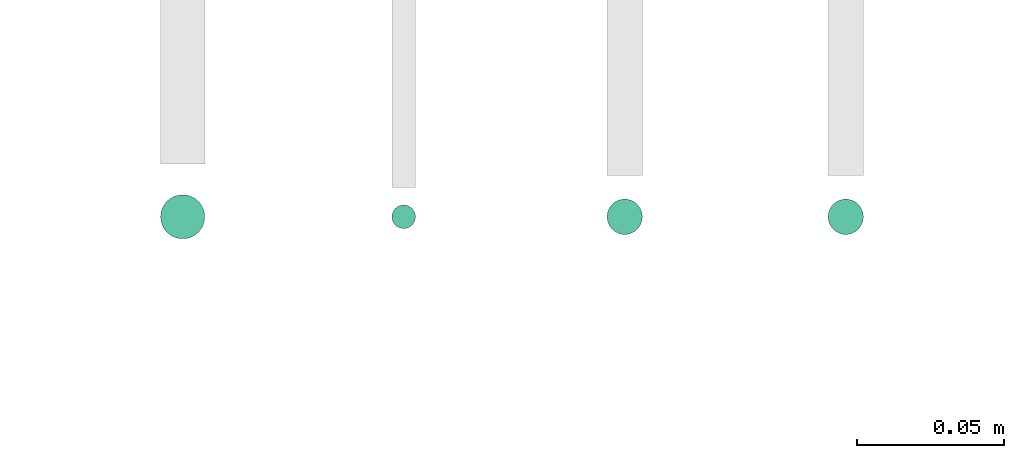
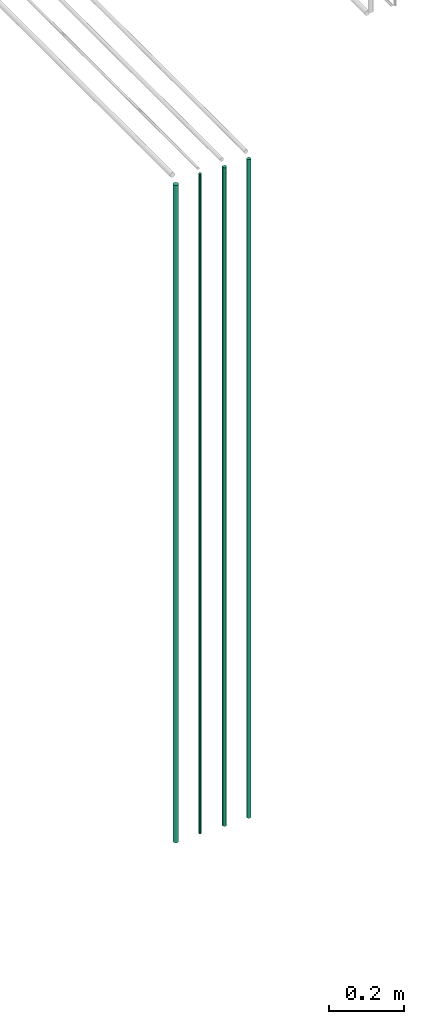
# One storey, part 2 of 331: 4 flow segments.
"""IFC2X3 building model written with IfcOpenShell, lengths in millimetres."""

from ifc_helpers import new_model, entity, si_unit, converted_unit, derived_unit, direction, frame, frame_2d, origin, origin_2d_with_axis, place, context, subcontext, project, spatial, circle, extrude, type_object, element, save


model = new_model("IFC2X3")

# Units and contexts
model_context = context("Model", 3, precision=0.01, world=origin(), true_north=direction((6.12303176911189e-17, 1.0)))
body_context = subcontext(model_context, "Body", "Model", "MODEL_VIEW")
ifc_project = project(units=[si_unit("LENGTHUNIT", "METRE", prefix="MILLI"), si_unit("AREAUNIT", "SQUARE_METRE"), si_unit("VOLUMEUNIT", "CUBIC_METRE"), converted_unit("PLANEANGLEUNIT", "DEGREE", entity("IfcRatioMeasure", 0.0174532925199433), si_unit("PLANEANGLEUNIT", "RADIAN"), dimensions=[0, 0, 0, 0, 0, 0, 0]), si_unit("MASSUNIT", "GRAM", prefix="KILO"), derived_unit("MASSDENSITYUNIT", [(si_unit("MASSUNIT", "GRAM", prefix="KILO"), 1), (si_unit("LENGTHUNIT", "METRE"), -3)]), derived_unit("MOMENTOFINERTIAUNIT", [(si_unit("LENGTHUNIT", "METRE"), 4)]), si_unit("TIMEUNIT", "SECOND"), si_unit("FREQUENCYUNIT", "HERTZ"), si_unit("THERMODYNAMICTEMPERATUREUNIT", "DEGREE_CELSIUS"), derived_unit("THERMALTRANSMITTANCEUNIT", [(si_unit("MASSUNIT", "GRAM", prefix="KILO"), 1), (si_unit("THERMODYNAMICTEMPERATUREUNIT", "KELVIN"), -1), (si_unit("TIMEUNIT", "SECOND"), -3)]), derived_unit("VOLUMETRICFLOWRATEUNIT", [(si_unit("LENGTHUNIT", "METRE"), 3), (si_unit("TIMEUNIT", "SECOND"), -1)]), derived_unit("MASSFLOWRATEUNIT", [(si_unit("MASSUNIT", "GRAM", prefix="KILO"), 1), (si_unit("TIMEUNIT", "SECOND"), -1)]), derived_unit("ROTATIONALFREQUENCYUNIT", [(si_unit("TIMEUNIT", "SECOND"), -1)]), si_unit("ELECTRICCURRENTUNIT", "AMPERE"), si_unit("ELECTRICVOLTAGEUNIT", "VOLT"), si_unit("POWERUNIT", "WATT"), si_unit("FORCEUNIT", "NEWTON", prefix="KILO"), si_unit("ILLUMINANCEUNIT", "LUX"), si_unit("LUMINOUSFLUXUNIT", "LUMEN"), si_unit("LUMINOUSINTENSITYUNIT", "CANDELA"), derived_unit("USERDEFINED", [(si_unit("MASSUNIT", "GRAM", prefix="KILO"), -1), (si_unit("LENGTHUNIT", "METRE"), -2), (si_unit("TIMEUNIT", "SECOND"), 3), (si_unit("LUMINOUSFLUXUNIT", "LUMEN"), 1)]), derived_unit("LINEARVELOCITYUNIT", [(si_unit("LENGTHUNIT", "METRE"), 1), (si_unit("TIMEUNIT", "SECOND"), -1)]), si_unit("PRESSUREUNIT", "PASCAL"), derived_unit("USERDEFINED", [(si_unit("LENGTHUNIT", "METRE"), -2), (si_unit("MASSUNIT", "GRAM", prefix="KILO"), 1), (si_unit("TIMEUNIT", "SECOND"), -2)]), derived_unit("LINEARFORCEUNIT", [(si_unit("MASSUNIT", "GRAM", prefix="KILO"), 1), (si_unit("LENGTHUNIT", "METRE"), 1), (si_unit("TIMEUNIT", "SECOND"), -2), (si_unit("LENGTHUNIT", "METRE"), -1)]), derived_unit("PLANARFORCEUNIT", [(si_unit("MASSUNIT", "GRAM", prefix="KILO"), 1), (si_unit("LENGTHUNIT", "METRE"), 1), (si_unit("TIMEUNIT", "SECOND"), -2), (si_unit("LENGTHUNIT", "METRE"), -2)])], contexts=[model_context])

# Site, building, storey
site_placement = place(None, frame((0.0, -0.00077364408347762, 0.0)))
site = spatial("IfcSite", under=ifc_project, at=site_placement, CompositionType="ELEMENT")
building_placement = place(site_placement, origin())
building = spatial("IfcBuilding", under=site, at=building_placement, CompositionType="ELEMENT")
storey_placement = place(building_placement, origin())
storey = spatial("IfcBuildingStorey", under=building, at=storey_placement, CompositionType="ELEMENT", Elevation=0.0)

# Flow segments
pipe_segment_type = type_object("IfcPipeSegmentType", PredefinedType="NOTDEFINED")
flow_segment_1_placement = place(storey_placement, frame((20612.0132627125, 3194.5252915914, 12990.0)))
element("IfcFlowSegment", 1, at=flow_segment_1_placement, inside=storey, type_object=pipe_segment_type, context=body_context, shape_type="SweptSolid", body=[
    extrude(circle(Radius=7.5, at=frame_2d((0.0, 5.41433564649196e-13), x_axis=(1.0, 0.0))), frame((9.09527223591419, 9.09527223591528, 0.0)), (0.0, 0.0, 1.0), 2142.00000000001),
])
flow_segment_2_placement = place(storey_placement, frame((20690.5132627125, 3198.0252915914, 12990.0)))
element("IfcFlowSegment", 2, at=flow_segment_2_placement, inside=storey, type_object=pipe_segment_type, context=body_context, shape_type="SweptSolid", body=[
    extrude(circle(Radius=4.0, at=origin_2d_with_axis()), frame((5.59527223591499, 5.59527223591607, 0.0)), (0.0, 0.0, 1.0), 2150.00000000001),
])
for number, where in (
    (3, (20763.5132627125, 3196.0252915914, 12990.0)),
    (4, (20838.5132627125, 3196.0252915914, 12990.0)),
):
    element("IfcFlowSegment", number, at=place(storey_placement, frame(where)), inside=storey, type_object=pipe_segment_type, context=body_context, shape_type="SweptSolid", body=[
        extrude(circle(Radius=6.0, at=origin_2d_with_axis()), frame((7.59527223591454, 7.59527223591616, 0.0)), (0.0, 0.0, 1.0), 2146.00000000001),
    ])

save(model, "model.ifc")
